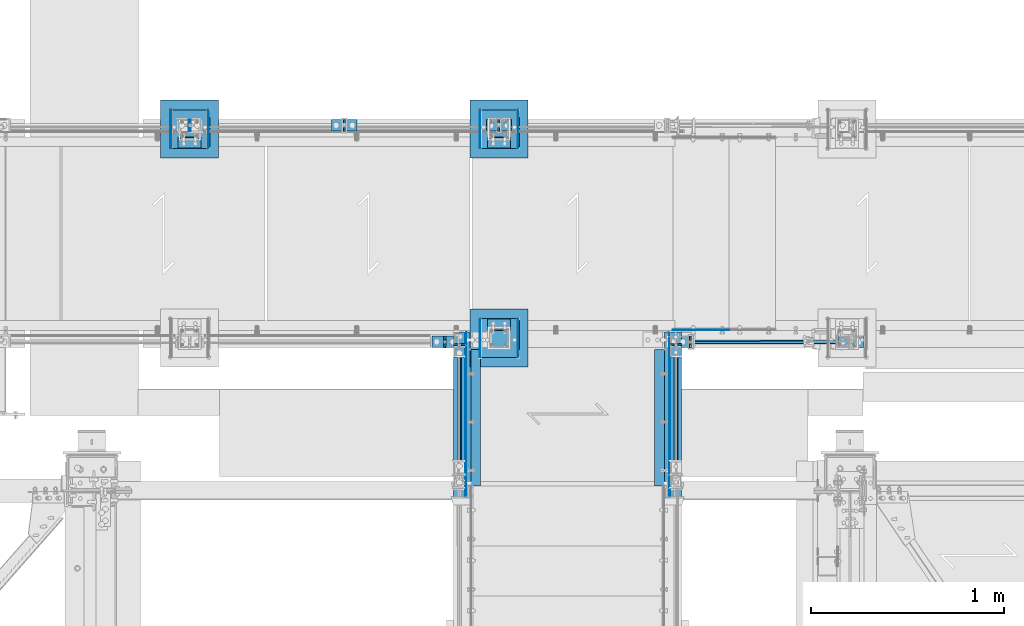
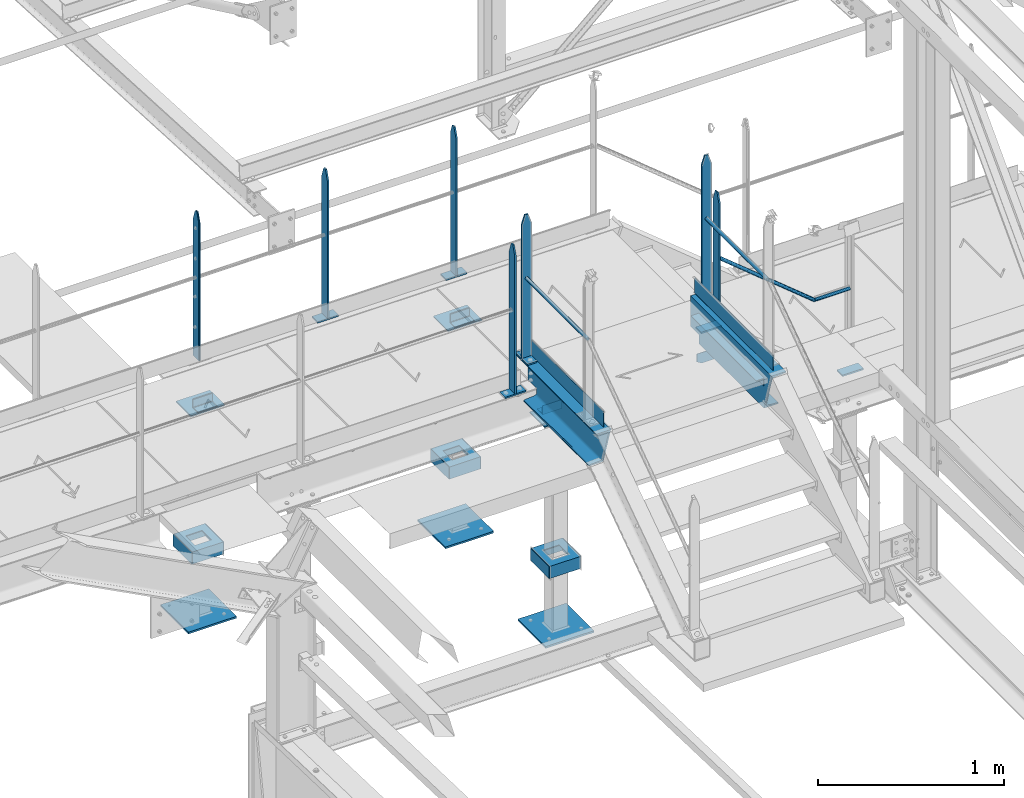
# One storey, part 97 of 496: 43 beams, 1 member, 18 elements without a shape of their own.
"""IFC2X3 building model written with IfcOpenShell, lengths in millimetres."""

from ifc_helpers import new_model, si_unit, frame, origin_with_axes, origin_2d_with_axis, place, context, subcontext, project, spatial, polyline, rectangle, hollow_circle, l_section, u_section, outline, extrude, boolean, clip, halfspace, material, type_object, element, aggregate, save


model = new_model("IFC2X3")

# Units and contexts
model_context = context("Model", 3, precision=1e-05, world=origin_with_axes())
body_context = subcontext(model_context, "Body", "Model", "MODEL_VIEW")
ifc_project = project(units=[si_unit("LENGTHUNIT", "METRE", prefix="MILLI"), si_unit("AREAUNIT", "SQUARE_METRE"), si_unit("VOLUMEUNIT", "CUBIC_METRE"), si_unit("MASSUNIT", "GRAM", prefix="KILO"), si_unit("TIMEUNIT", "SECOND"), si_unit("PLANEANGLEUNIT", "RADIAN"), si_unit("SOLIDANGLEUNIT", "STERADIAN"), si_unit("THERMODYNAMICTEMPERATUREUNIT", "DEGREE_CELSIUS"), si_unit("LUMINOUSINTENSITYUNIT", "LUMEN")], contexts=[model_context])

# Site, building, storey
site_placement = place(None, origin_with_axes())
site = spatial("IfcSite", under=ifc_project, at=site_placement, CompositionType="ELEMENT")
building_placement = place(site_placement, origin_with_axes())
building = spatial("IfcBuilding", under=site, at=building_placement, Name="Undefined", CompositionType="ELEMENT")
storey_placement = place(building_placement, origin_with_axes())
storey = spatial("IfcBuildingStorey", under=building, at=storey_placement, Name="Undefined", CompositionType="ELEMENT", Elevation=0.0)

# Assembly, beam
assembly_1_placement = place(storey_placement, origin_with_axes())
assembly_1 = element("IfcElementAssembly", 1, at=assembly_1_placement, inside=storey, Name="MAIN COURANTE", AssemblyPlace="NOTDEFINED", PredefinedType="NOTDEFINED")
ifc_material_1 = material(Name="Undefined/S235-E24")
beam_type_1 = type_object("IfcBeamType", PredefinedType="NOTDEFINED")
beam_1_placement = place(assembly_1_placement, frame((21439.9851177233, 15970.0000882977, 8705.00000001012), z_axis=(0.0, -1.0, 0.0), x_axis=(-1.0, 0.0, 0.0)))
beam_1 = element("IfcBeam", 2, at=beam_1_placement, type_object=beam_type_1, material=ifc_material_1, context=body_context, shape_type="SweptSolid", body=[
    extrude(rectangle(XDim=10.0, YDim=60.0, at=origin_2d_with_axis()), frame((130.0, 0.0, 0.0), z_axis=(-1.0, 0.0, 0.0), x_axis=(0.0, -1.0, 0.0)), (0.0, 0.0, 1.0), 130.0),
])
aggregate(assembly_1, [beam_1])

assembly_2_placement = place(storey_placement, origin_with_axes())
assembly_2 = element("IfcElementAssembly", 3, at=assembly_2_placement, inside=storey, Name="MONTANT", AssemblyPlace="NOTDEFINED", PredefinedType="NOTDEFINED")
beam_2_placement = place(assembly_2_placement, frame((21374.9851177233, 15970.0000882977, 9677.59999847), z_axis=(0.0, 1.0, 0.0), x_axis=(0.0, 0.0, -1.0)))
beam_2 = element("IfcBeam", 4, at=beam_2_placement, type_object=beam_type_1, material=ifc_material_1, Name="MONTANT", context=body_context, shape_type="Clipping", body=[
    clip(clip(extrude(rectangle(XDim=10.0, YDim=60.0, at=origin_2d_with_axis()), frame((967.599838858492, 0.0, 0.0), z_axis=(-1.0, 0.0, 0.0), x_axis=(0.0, -1.0, 0.0)), (0.0, 0.0, 1.0), 967.6), halfspace(frame((-119.99851575355, 5.0, -30.0), z_axis=(-0.316227766016838, 0.0, 0.948683298050514), x_axis=(0.948683298050514, 0.0, 0.316227766016838)), False)), halfspace(frame((60.0014842464498, 5.0, -30.0), z_axis=(-0.316227766016838, 0.0, -0.948683298050514), x_axis=(-0.948683298050514, 0.0, 0.316227766016838)), False)),
])
aggregate(assembly_2, [beam_2])

# Assembly, beams
assembly_3_placement = place(storey_placement, origin_with_axes())
assembly_3 = element("IfcElementAssembly", 5, at=assembly_3_placement, inside=storey, Name="MAIN COURANTE", AssemblyPlace="NOTDEFINED", PredefinedType="NOTDEFINED")
beam_3_placement = place(assembly_3_placement, frame((22660.0061849194, 15970.0000882977, 8705.00015961151), z_axis=(0.0, -1.0, 0.0), x_axis=(-1.0, 0.0, 0.0)))
beam_3 = element("IfcBeam", 6, at=beam_3_placement, type_object=beam_type_1, material=ifc_material_1, context=body_context, shape_type="SweptSolid", body=[
    extrude(rectangle(XDim=10.0, YDim=60.0, at=origin_2d_with_axis()), frame((130.0, 0.0, 0.0), z_axis=(-1.0, 0.0, 0.0), x_axis=(0.0, -1.0, 0.0)), (0.0, 0.0, 1.0), 130.0),
])
beam_4_placement = place(assembly_3_placement, frame((22645.0061849194, 15970.0000882977, 9582.39164232764), z_axis=(0.0, 1.0, 0.0), x_axis=(0.0, 0.0, -1.0)))
beam_4 = element("IfcBeam", 7, at=beam_4_placement, type_object=beam_type_1, material=ifc_material_1, Name="MONTANT", context=body_context, shape_type="Clipping", body=[
    clip(clip(clip(extrude(rectangle(XDim=10.0, YDim=60.0, at=origin_2d_with_axis()), frame((872.391482716137, 0.0, 0.0), z_axis=(-1.0, 0.0, 0.0), x_axis=(0.0, -1.0, 0.0)), (0.0, 0.0, 1.0), 876.53), halfspace(frame((-119.99851575355, -5.0, -30.0), z_axis=(-0.316227766016838, 0.0, 0.948683298050514), x_axis=(0.0, 1.0, 0.0)), False)), halfspace(frame((60.0014842464498, -5.0, -30.0), z_axis=(-0.316227766016838, 0.0, -0.948683298050514), x_axis=(0.0, 1.0, 0.0)), False)), halfspace(frame((7.28321514399249, -8.88829265710956, 0.0), z_axis=(0.773488973625628, 0.633809756693262, 0.0), x_axis=(0.0, 0.0, 1.0)), True)),
])
beam_5_placement = place(assembly_3_placement, frame((23540.0061849194, 15970.0000882977, 8114.9999407569), z_axis=(0.0, -1.0, 0.0), x_axis=(-1.0, 0.0, 0.0)))
beam_5 = element("IfcBeam", 8, at=beam_5_placement, type_object=beam_type_1, material=ifc_material_1, context=body_context, shape_type="SweptSolid", body=[
    extrude(rectangle(XDim=10.0, YDim=60.0, at=origin_2d_with_axis()), frame((130.0, 0.0, 0.0), z_axis=(-1.0, 0.0, 0.0), x_axis=(0.0, -1.0, 0.0)), (0.0, 0.0, 1.0), 130.0),
])

assembly_4_placement = place(storey_placement, origin_with_axes())
assembly_4 = element("IfcElementAssembly", 9, at=assembly_4_placement, inside=storey, Name="MAIN COURANTE", AssemblyPlace="NOTDEFINED", PredefinedType="NOTDEFINED")
beam_6_placement = place(assembly_4_placement, frame((20919.9961849193, 17089.9938659712, 8705.00000001012), z_axis=(0.0, 1.0, 0.0), x_axis=(-1.0, 0.0, 0.0)))
beam_6 = element("IfcBeam", 10, at=beam_6_placement, type_object=beam_type_1, material=ifc_material_1, context=body_context, shape_type="SweptSolid", body=[
    extrude(rectangle(XDim=10.0, YDim=60.0, at=origin_2d_with_axis()), frame((130.0, 0.0, 0.0), z_axis=(-1.0, 0.0, 0.0), x_axis=(0.0, -1.0, 0.0)), (0.0, 0.0, 1.0), 130.0),
])
beam_7_placement = place(assembly_4_placement, frame((20854.9961849193, 17089.9938659712, 9677.59999847), z_axis=(0.0, -1.0, 0.0), x_axis=(0.0, 0.0, -1.0)))
beam_7 = element("IfcBeam", 11, at=beam_7_placement, type_object=beam_type_1, material=ifc_material_1, Name="MONTANT", context=body_context, shape_type="Clipping", body=[
    clip(clip(extrude(rectangle(XDim=10.0, YDim=60.0, at=origin_2d_with_axis()), frame((967.59999845988, 0.0, 0.0), z_axis=(-1.0, 0.0, 0.0), x_axis=(0.0, -1.0, 0.0)), (0.0, 0.0, 1.0), 967.6), halfspace(frame((-120.0, 5.0, -30.0), z_axis=(-0.316227766016838, 0.0, 0.948683298050514), x_axis=(0.948683298050514, 0.0, 0.316227766016838)), False)), halfspace(frame((60.0, 5.0, -30.0), z_axis=(-0.316227766016838, 0.0, -0.948683298050514), x_axis=(-0.948683298050514, 0.0, 0.316227766016838)), False)),
])
beam_8_placement = place(assembly_4_placement, frame((21719.9961849193, 17089.9938659712, 8705.00000001012), z_axis=(0.0, 1.0, 0.0), x_axis=(-1.0, 0.0, 0.0)))
beam_8 = element("IfcBeam", 12, at=beam_8_placement, type_object=beam_type_1, material=ifc_material_1, context=body_context, shape_type="SweptSolid", body=[
    extrude(rectangle(XDim=10.0, YDim=60.0, at=origin_2d_with_axis()), frame((130.0, 0.0, 0.0), z_axis=(-1.0, 0.0, 0.0), x_axis=(0.0, -1.0, 0.0)), (0.0, 0.0, 1.0), 130.0),
])

assembly_5_placement = place(storey_placement, origin_with_axes())
assembly_5 = element("IfcElementAssembly", 13, at=assembly_5_placement, inside=storey, Name="MAIN COURANTE", AssemblyPlace="NOTDEFINED", PredefinedType="NOTDEFINED")
beam_9_placement = place(assembly_5_placement, frame((21449.9863365012, 16019.9996531834, 8915.0), z_axis=(-1.0, 0.0, 0.0), x_axis=(0.0, -1.0, 0.0)))
beam_9 = element("IfcBeam", 14, at=beam_9_placement, type_object=beam_type_1, material=ifc_material_1, context=body_context, shape_type="SweptSolid", body=[
    extrude(rectangle(XDim=10.0, YDim=60.0, at=origin_2d_with_axis()), frame((130.0, 0.0, 0.0), z_axis=(-1.0, 0.0, 0.0), x_axis=(0.0, -1.0, 0.0)), (0.0, 0.0, 1.0), 130.0),
])
beam_10_placement = place(assembly_5_placement, frame((21449.9862112009, 15954.9996531834, 9857.59999847), z_axis=(-0.99999999999782, -2.08799998896818e-06, 0.0), x_axis=(0.0, 0.0, -1.0)))
beam_10 = element("IfcBeam", 15, at=beam_10_placement, type_object=beam_type_1, material=ifc_material_1, Name="MONTANT", context=body_context, shape_type="Clipping", body=[
    clip(clip(extrude(rectangle(XDim=10.0, YDim=60.0, at=origin_2d_with_axis()), frame((937.599998469999, 0.0, 0.0), z_axis=(-1.0, 0.0, 0.0), x_axis=(0.0, -1.0, 0.0)), (0.0, 0.0, 1.0), 937.6), halfspace(frame((-119.999937359999, -4.99999999999636, -30.0), z_axis=(-0.316227766016837, -1.98085072276202e-06, 0.948683298048446), x_axis=(-6.26399999950979e-06, 0.999999999980381, -3.63797880701241e-15)), False)), halfspace(frame((60.0, -5.0, -30.0), z_axis=(-0.316227469016822, 1.98084886235393e-06, -0.948683397048399), x_axis=(6.26399999950979e-06, 0.999999999980381, -3.63797880701241e-15)), False)),
])

assembly_6_placement = place(storey_placement, origin_with_axes())
assembly_6 = element("IfcElementAssembly", 16, at=assembly_6_placement, inside=storey, Name="MAIN COURANTE", AssemblyPlace="NOTDEFINED", PredefinedType="NOTDEFINED")
beam_11_placement = place(assembly_6_placement, frame((22569.9936634988, 16019.9996531834, 8915.0), z_axis=(1.0, 0.0, 0.0), x_axis=(0.0, -1.0, 0.0)))
beam_11 = element("IfcBeam", 17, at=beam_11_placement, type_object=beam_type_1, material=ifc_material_1, context=body_context, shape_type="SweptSolid", body=[
    extrude(rectangle(XDim=10.0, YDim=60.0, at=origin_2d_with_axis()), frame((130.0, 0.0, 0.0), z_axis=(-1.0, 0.0, 0.0), x_axis=(0.0, -1.0, 0.0)), (0.0, 0.0, 1.0), 130.0),
])
beam_12_placement = place(assembly_6_placement, frame((22569.9937887991, 15954.9996531834, 9857.59999847), z_axis=(0.999999999998558, -1.69800000185205e-06, 0.0), x_axis=(0.0, 0.0, -1.0)))
beam_12 = element("IfcBeam", 18, at=beam_12_placement, type_object=beam_type_1, material=ifc_material_1, Name="MONTANT", context=body_context, shape_type="Clipping", body=[
    clip(clip(extrude(rectangle(XDim=10.0, YDim=60.0, at=origin_2d_with_axis()), frame((937.599998469999, 0.0, 0.0), z_axis=(-1.0, 0.0, 0.0), x_axis=(0.0, -1.0, 0.0)), (0.0, 0.0, 1.0), 937.6), halfspace(frame((-119.999937359999, 4.99999999999818, -30.0), z_axis=(-0.316227766016843, 1.98085072621335e-06, 0.948683298048444), x_axis=(0.948683298050514, 0.0, 0.316227766016838)), False)), halfspace(frame((60.0, 5.0, -30.0), z_axis=(-0.316227469016822, -1.98084886580522e-06, -0.948683397048399), x_axis=(-0.948683298050514, 0.0, 0.316227766016838)), False)),
])

# Beam
beam_13_placement = place(assembly_4_placement, frame((21654.9961849193, 17089.9938659712, 9677.59999847), z_axis=(0.0, -1.0, 0.0), x_axis=(0.0, 0.0, -1.0)))
beam_13 = element("IfcBeam", 19, at=beam_13_placement, type_object=beam_type_1, material=ifc_material_1, Name="MONTANT", context=body_context, shape_type="Clipping", body=[
    clip(clip(extrude(rectangle(XDim=10.0, YDim=60.0, at=origin_2d_with_axis()), frame((967.59999845988, 0.0, 0.0), z_axis=(-1.0, 0.0, 0.0), x_axis=(0.0, -1.0, 0.0)), (0.0, 0.0, 1.0), 967.6), halfspace(frame((-120.0, 5.0, -30.0), z_axis=(-0.316227766016838, 0.0, 0.948683298050514), x_axis=(0.948683298050514, 0.0, 0.316227766016838)), False)), halfspace(frame((60.0, 5.0, -30.0), z_axis=(-0.316227766016838, 0.0, -0.948683298050514), x_axis=(-0.948683298050514, 0.0, 0.316227766016838)), False)),
])

beam_type_2 = type_object("IfcBeamType", PredefinedType="NOTDEFINED")
beam_14_placement = place(assembly_3_placement, frame((23250.3145397259, 15970.0002031579, 8653.80000001012), z_axis=(0.0, -1.0, 0.0), x_axis=(1.0, 0.0, 0.0)))
beam_14 = element("IfcBeam", 20, at=beam_14_placement, type_object=beam_type_2, material=ifc_material_1, Name="LISSE", context=body_context, shape_type="Clipping", body=[
    clip(extrude(hollow_circle(Radius=10.64999962, WallThickness=2.0, at=origin_2d_with_axis()), frame((219.691645193617, 1.81898940354586e-12, 0.0), z_axis=(-1.0, 0.0, 0.0), x_axis=(0.0, -1.0, 0.0)), (0.0, 0.0, 1.0), 223.54), halfspace(frame((3.80609846942389, 10.6499996200018, 0.000112519470349071), z_axis=(0.941671113820085, -0.336534564935766, -5.79127735785473e-07), x_axis=(-0.336534564313756, -0.941671114042557, 0.0)), True)),
])

beam_15_placement = place(assembly_6_placement, frame((22569.9936634988, 15290.0038659711, 9438.8), z_axis=(0.999999999998558, -1.69800000185205e-06, 0.0), x_axis=(1.69800000215235e-06, 0.999999999998558, 0.0)))
beam_15 = element("IfcBeam", 21, at=beam_15_placement, type_object=beam_type_2, material=ifc_material_1, Name="LISSE", context=body_context, shape_type="SweptSolid", body=[
    extrude(hollow_circle(Radius=10.64999962, WallThickness=2.0, at=origin_2d_with_axis()), frame((659.995802516527, 1.81898940354586e-12, -1.3975954744526e-19), z_axis=(-1.0, 0.0, 0.0), x_axis=(0.0, -1.0, 0.0)), (0.0, 0.0, 1.0), 660.0),
])

beam_16_placement = place(assembly_5_placement, frame((21449.9863365012, 15290.0038659711, 9438.8), z_axis=(-0.99999999999782, -2.08799998896818e-06, 0.0), x_axis=(-1.15500000027281e-06, 0.999999999999333, 0.0)))
beam_16 = element("IfcBeam", 22, at=beam_16_placement, type_object=beam_type_2, material=ifc_material_1, Name="LISSE", context=body_context, shape_type="SweptSolid", body=[
    extrude(hollow_circle(Radius=10.64999962, WallThickness=2.0, at=origin_2d_with_axis()), frame((659.995802516527, 1.81898940354586e-12, -1.3975954744526e-19), z_axis=(-1.0, 0.0, 0.0), x_axis=(0.0, -1.0, 0.0)), (0.0, 0.0, 1.0), 660.0),
])

# Member
member_type = type_object("IfcMemberType", PredefinedType="NOTDEFINED")
member_placement = place(assembly_3_placement, frame((23250.3145397259, 15970.0040747151, 8653.80000001012), z_axis=(0.0, 1.0, 0.0), x_axis=(-0.773488973625643, 0.0, 0.633809756693245)))
member = element("IfcMember", 23, at=member_placement, type_object=member_type, material=ifc_material_1, Name="LISSE", context=body_context, shape_type="Clipping", body=[
    clip(clip(extrude(hollow_circle(Radius=10.64999962, WallThickness=2.0, at=origin_2d_with_axis()), frame((794.709650012954, 0.0, 0.0), z_axis=(-1.0, 0.0, 0.0), x_axis=(0.0, -1.0, 0.0)), (0.0, 0.0, 1.0), 813.31), halfspace(frame((787.048146301975, 13.3552820560435, -0.00398641746141948), z_axis=(-0.773488973625642, 0.633809756693246, 0.0), x_axis=(-0.633809756693246, -0.773488973625642, 0.0)), True)), halfspace(frame((3.80609846935113, 10.6499996200037, -0.00398641746141948), z_axis=(-0.941671114042557, 0.336534564313756, 0.0), x_axis=(-0.336534564313756, -0.941671114042557, 0.0)), False)),
])

aggregate(assembly_3, [beam_3, beam_4, beam_5, member, beam_14])

# Assembly, beam
assembly_7_placement = place(storey_placement, origin_with_axes())
assembly_7 = element("IfcElementAssembly", 24, at=assembly_7_placement, inside=storey, AssemblyPlace="NOTDEFINED", PredefinedType="NOTDEFINED")
beam_type_3 = type_object("IfcBeamType", PredefinedType="NOTDEFINED")
beam_17_placement = place(assembly_7_placement, frame((20205.0, 17219.9998774248, 7056.0), z_axis=(0.0, 0.0, 1.0), x_axis=(-1.0, 0.0, 0.0)))
beam_17 = element("IfcBeam", 25, at=beam_17_placement, type_object=beam_type_3, material=ifc_material_1, context=body_context, shape_type="SweptSolid", body=[
    extrude(outline(polyline([(0.0, 0.0), (300.0, 0.0), (300.0, 300.0), (0.0, 300.0), (0.0, 0.0)])), frame((0.0, 0.0, -6.0), z_axis=(0.0, 0.0, 1.0), x_axis=(1.0, 0.0, 0.0)), (0.0, 0.0, 1.0), 12.0),
])

assembly_8_placement = place(storey_placement, origin_with_axes())
assembly_8 = element("IfcElementAssembly", 26, at=assembly_8_placement, inside=storey, AssemblyPlace="NOTDEFINED", PredefinedType="NOTDEFINED")
beam_18_placement = place(assembly_8_placement, frame((21805.0, 15840.0001225752, 7056.0), z_axis=(0.0, 0.0, -1.0), x_axis=(-1.0, 0.0, 0.0)))
beam_18 = element("IfcBeam", 27, at=beam_18_placement, type_object=beam_type_3, material=ifc_material_1, context=body_context, shape_type="SweptSolid", body=[
    extrude(outline(polyline([(0.0, 0.0), (300.0, 0.0), (300.0, 300.0), (0.0, 300.0), (0.0, 0.0)])), frame((0.0, 0.0, -6.0), z_axis=(0.0, 0.0, 1.0), x_axis=(1.0, 0.0, 0.0)), (0.0, 0.0, 1.0), 12.0),
])

assembly_9_placement = place(storey_placement, origin_with_axes())
assembly_9 = element("IfcElementAssembly", 28, at=assembly_9_placement, inside=storey, AssemblyPlace="NOTDEFINED", PredefinedType="NOTDEFINED")
beam_19_placement = place(assembly_9_placement, frame((21805.0, 17219.9998774248, 7056.0), z_axis=(0.0, 0.0, 1.0), x_axis=(-1.0, 0.0, 0.0)))
beam_19 = element("IfcBeam", 29, at=beam_19_placement, type_object=beam_type_3, material=ifc_material_1, context=body_context, shape_type="SweptSolid", body=[
    extrude(outline(polyline([(0.0, 0.0), (300.0, 0.0), (300.0, 300.0), (0.0, 300.0), (0.0, 0.0)])), frame((0.0, 0.0, -6.0), z_axis=(0.0, 0.0, 1.0), x_axis=(1.0, 0.0, 0.0)), (0.0, 0.0, 1.0), 12.0),
])

# Beam
beam_type_4 = type_object("IfcBeamType", PredefinedType="NOTDEFINED")
beam_20_placement = place(assembly_5_placement, frame((21482.4987221813, 16019.9997158234, 8970.0), z_axis=(0.0, 0.0, -1.0), x_axis=(0.0, -1.0, 0.0)))
beam_20 = element("IfcBeam", 30, at=beam_20_placement, type_object=beam_type_4, material=ifc_material_1, context=body_context, shape_type="SweptSolid", body=[
    extrude(rectangle(XDim=5.0, YDim=100.0, at=origin_2d_with_axis()), frame((844.999940076701, 0.0, 0.0), z_axis=(-1.0, 0.0, 0.0), x_axis=(0.0, -1.0, 0.0)), (0.0, 0.0, 1.0), 845.0),
])

aggregate(assembly_5, [beam_16, beam_20, beam_9, beam_10])

beam_21_placement = place(assembly_6_placement, frame((22537.4812778187, 16019.9997158234, 8970.0), z_axis=(0.0, 0.0, -1.0), x_axis=(0.0, -1.0, 0.0)))
beam_21 = element("IfcBeam", 31, at=beam_21_placement, type_object=beam_type_4, material=ifc_material_1, context=body_context, shape_type="SweptSolid", body=[
    extrude(rectangle(XDim=5.0, YDim=100.0, at=origin_2d_with_axis()), frame((844.999940076701, 0.0, 0.0), z_axis=(-1.0, 0.0, 0.0), x_axis=(0.0, -1.0, 0.0)), (0.0, 0.0, 1.0), 845.0),
])

aggregate(assembly_6, [beam_15, beam_21, beam_11, beam_12])

beam_type_5 = type_object("IfcBeamType", PredefinedType="NOTDEFINED")
beam_22_placement = place(assembly_4_placement, frame((20057.4961849193, 17089.9938659712, 9677.59999847), z_axis=(0.0, -1.0, 0.0), x_axis=(0.0, 0.0, -1.0)))
beam_22 = element("IfcBeam", 32, at=beam_22_placement, type_object=beam_type_5, material=ifc_material_1, Name="MONTANT", context=body_context, shape_type="Clipping", body=[
    clip(clip(extrude(rectangle(XDim=5.0, YDim=60.0, at=origin_2d_with_axis()), frame((967.59999845988, 0.0, 0.0), z_axis=(-1.0, 0.0, 0.0), x_axis=(0.0, -1.0, 0.0)), (0.0, 0.0, 1.0), 967.6), halfspace(frame((-120.0, -5.0, -30.0), z_axis=(-0.316227766016838, 0.0, 0.948683298050514), x_axis=(0.0, 1.0, 0.0)), False)), halfspace(frame((60.0, -5.0, -30.0), z_axis=(-0.316227766016838, 0.0, -0.948683298050514), x_axis=(0.0, 1.0, 0.0)), False)),
])

aggregate(assembly_4, [beam_22, beam_6, beam_7, beam_8, beam_13])

# Assembly, beam
assembly_10_placement = place(storey_placement, origin_with_axes())
assembly_10 = element("IfcElementAssembly", 33, at=assembly_10_placement, inside=storey, Name="MAIN COURANTE", AssemblyPlace="NOTDEFINED", PredefinedType="NOTDEFINED")
beam_23_placement = place(assembly_10_placement, frame((20052.4961849157, 17089.9938659712, 9677.59999847), z_axis=(0.0, -1.0, 0.0), x_axis=(0.0, 0.0, -1.0)))
beam_23 = element("IfcBeam", 34, at=beam_23_placement, type_object=beam_type_5, material=ifc_material_1, Name="MONTANT", context=body_context, shape_type="Clipping", body=[
    clip(clip(extrude(rectangle(XDim=5.0, YDim=60.0, at=origin_2d_with_axis()), frame((967.59999845988, 0.0, 0.0), z_axis=(-1.0, 0.0, 0.0), x_axis=(0.0, -1.0, 0.0)), (0.0, 0.0, 1.0), 967.6), halfspace(frame((-120.0, 5.0, -30.0), z_axis=(-0.316227766016838, 0.0, 0.948683298050514), x_axis=(0.948683298050514, 0.0, 0.316227766016838)), False)), halfspace(frame((60.0, 5.0, -30.0), z_axis=(-0.316227766016838, 0.0, -0.948683298050514), x_axis=(-0.948683298050514, 0.0, 0.316227766016838)), False)),
])
aggregate(assembly_10, [beam_23])

# Beam
beam_type_6 = type_object("IfcBeamType", PredefinedType="NOTDEFINED")
beam_24_placement = place(assembly_7_placement, frame((20160.0, 17129.9993585039, 8436.00011661134), z_axis=(0.0, 0.0, 1.0), x_axis=(-1.0, 0.0, 0.0)))
beam_24 = element("IfcBeam", 35, at=beam_24_placement, type_object=beam_type_6, material=ifc_material_1, context=body_context, shape_type="SweptSolid", body=[
    extrude(outline(polyline([(0.0, 0.0), (210.0, 0.0), (210.0, 159.999481201172), (0.0, 159.999481201172), (0.0, 0.0)])), frame((0.0, 0.0, -4.0), z_axis=(0.0, 0.0, 1.0), x_axis=(1.0, 0.0, 0.0)), (0.0, 0.0, 1.0), 8.0),
])

beam_25_placement = place(assembly_8_placement, frame((21760.0, 15930.0006414961, 8436.00011661134), z_axis=(0.0, 0.0, -1.0), x_axis=(-1.0, 0.0, 0.0)))
beam_25 = element("IfcBeam", 36, at=beam_25_placement, type_object=beam_type_6, material=ifc_material_1, context=body_context, shape_type="SweptSolid", body=[
    extrude(outline(polyline([(0.0, 0.0), (210.0, 0.0), (210.0, 159.999481201172), (0.0, 159.999481201172), (0.0, 0.0)])), frame((0.0, 0.0, -4.0), z_axis=(0.0, 0.0, 1.0), x_axis=(1.0, 0.0, 0.0)), (0.0, 0.0, 1.0), 8.0),
])

beam_26_placement = place(assembly_9_placement, frame((21760.0, 17129.9993585039, 8436.00011661134), z_axis=(0.0, 0.0, 1.0), x_axis=(-1.0, 0.0, 0.0)))
beam_26 = element("IfcBeam", 37, at=beam_26_placement, type_object=beam_type_6, material=ifc_material_1, context=body_context, shape_type="SweptSolid", body=[
    extrude(outline(polyline([(0.0, 0.0), (210.0, 0.0), (210.0, 159.999481201172), (0.0, 159.999481201172), (0.0, 0.0)])), frame((0.0, 0.0, -4.0), z_axis=(0.0, 0.0, 1.0), x_axis=(1.0, 0.0, 0.0)), (0.0, 0.0, 1.0), 8.0),
])

beam_type_7 = type_object("IfcBeamType", PredefinedType="NOTDEFINED")
beam_27_placement = place(assembly_7_placement, frame((20153.0, 16969.9998774248, 7500.0), z_axis=(0.0, 0.0, 1.0), x_axis=(0.0, 1.0, 0.0)))
beam_27 = element("IfcBeam", 38, at=beam_27_placement, type_object=beam_type_7, material=ifc_material_1, Name="BORD", context=body_context, shape_type="SweptSolid", body=[
    extrude(rectangle(XDim=4.0, YDim=80.0, at=origin_2d_with_axis()), frame((200.0, 0.0, 0.0), z_axis=(-1.0, 0.0, 0.0), x_axis=(0.0, -1.0, 0.0)), (0.0, 0.0, 1.0), 200.0),
])

beam_28_placement = place(assembly_7_placement, frame((19957.0, 16969.9998774248, 7500.0), z_axis=(0.0, 0.0, 1.0), x_axis=(0.0, 1.0, 0.0)))
beam_28 = element("IfcBeam", 39, at=beam_28_placement, type_object=beam_type_7, material=ifc_material_1, Name="BORD", context=body_context, shape_type="SweptSolid", body=[
    extrude(rectangle(XDim=4.0, YDim=80.0, at=origin_2d_with_axis()), frame((200.0, 0.0, 0.0), z_axis=(-1.0, 0.0, 0.0), x_axis=(0.0, -1.0, 0.0)), (0.0, 0.0, 1.0), 200.0),
])

beam_29_placement = place(assembly_8_placement, frame((21753.0, 16090.0001225752, 7500.0), z_axis=(0.0, 0.0, 1.0), x_axis=(0.0, -1.0, 0.0)))
beam_29 = element("IfcBeam", 40, at=beam_29_placement, type_object=beam_type_7, material=ifc_material_1, Name="BORD", context=body_context, shape_type="SweptSolid", body=[
    extrude(rectangle(XDim=4.0, YDim=80.0, at=origin_2d_with_axis()), frame((200.0, 0.0, 0.0), z_axis=(-1.0, 0.0, 0.0), x_axis=(0.0, -1.0, 0.0)), (0.0, 0.0, 1.0), 200.0),
])

beam_30_placement = place(assembly_8_placement, frame((21557.0, 16090.0001225752, 7500.0), z_axis=(0.0, 0.0, 1.0), x_axis=(0.0, -1.0, 0.0)))
beam_30 = element("IfcBeam", 41, at=beam_30_placement, type_object=beam_type_7, material=ifc_material_1, Name="BORD", context=body_context, shape_type="SweptSolid", body=[
    extrude(rectangle(XDim=4.0, YDim=80.0, at=origin_2d_with_axis()), frame((200.0, 0.0, 0.0), z_axis=(-1.0, 0.0, 0.0), x_axis=(0.0, -1.0, 0.0)), (0.0, 0.0, 1.0), 200.0),
])

beam_31_placement = place(assembly_9_placement, frame((21753.0, 16969.9998774248, 7500.0), z_axis=(0.0, 0.0, 1.0), x_axis=(0.0, 1.0, 0.0)))
beam_31 = element("IfcBeam", 42, at=beam_31_placement, type_object=beam_type_7, material=ifc_material_1, Name="BORD", context=body_context, shape_type="SweptSolid", body=[
    extrude(rectangle(XDim=4.0, YDim=80.0, at=origin_2d_with_axis()), frame((200.0, 0.0, 0.0), z_axis=(-1.0, 0.0, 0.0), x_axis=(0.0, -1.0, 0.0)), (0.0, 0.0, 1.0), 200.0),
])

beam_32_placement = place(assembly_9_placement, frame((21557.0, 16969.9998774248, 7500.0), z_axis=(0.0, 0.0, 1.0), x_axis=(0.0, 1.0, 0.0)))
beam_32 = element("IfcBeam", 43, at=beam_32_placement, type_object=beam_type_7, material=ifc_material_1, Name="BORD", context=body_context, shape_type="SweptSolid", body=[
    extrude(rectangle(XDim=4.0, YDim=80.0, at=origin_2d_with_axis()), frame((200.0, 0.0, 0.0), z_axis=(-1.0, 0.0, 0.0), x_axis=(0.0, -1.0, 0.0)), (0.0, 0.0, 1.0), 200.0),
])

beam_type_8 = type_object("IfcBeamType", PredefinedType="NOTDEFINED")
beam_33_placement = place(assembly_7_placement, frame((19959.0, 17069.9998774248, 7500.0), z_axis=(0.0, -1.0, 0.0), x_axis=(1.0, 0.0, 0.0)))
beam_33 = element("IfcBeam", 44, at=beam_33_placement, type_object=beam_type_8, material=ifc_material_1, context=body_context, shape_type="CSG", body=[
    boolean("DIFFERENCE", extrude(u_section(Depth=200.0, FlangeWidth=80.0, WebThickness=4.0, FlangeThickness=4.0, at=origin_2d_with_axis()), frame((192.0, 0.0, 0.0), z_axis=(-1.0, 0.0, 0.0), x_axis=(0.0, -1.0, 0.0)), (0.0, 0.0, 1.0), 192.0), extrude(outline(polyline([(0.0, 0.0), (101.0, 0.0), (101.0, 101.0), (0.0, 101.0), (0.0, 0.0)])), frame((45.5, -42.5, -50.5), z_axis=(0.0, 1.0, 0.0), x_axis=(0.0, 0.0, 1.0)), (0.0, 0.0, 1.0), 85.0)),
])

aggregate(assembly_7, [beam_24, beam_27, beam_28, beam_33, beam_17])

beam_34_placement = place(assembly_8_placement, frame((21751.0, 15990.0001225752, 7500.0), z_axis=(0.0, 1.0, 0.0), x_axis=(-1.0, 0.0, 0.0)))
beam_34 = element("IfcBeam", 45, at=beam_34_placement, type_object=beam_type_8, material=ifc_material_1, context=body_context, shape_type="CSG", body=[
    boolean("DIFFERENCE", extrude(u_section(Depth=200.0, FlangeWidth=80.0, WebThickness=4.0, FlangeThickness=4.0, at=origin_2d_with_axis()), frame((192.0, 0.0, 0.0), z_axis=(-1.0, 0.0, 0.0), x_axis=(0.0, -1.0, 0.0)), (0.0, 0.0, 1.0), 192.0), extrude(outline(polyline([(0.0, 0.0), (101.0, 0.0), (101.0, 101.0), (0.0, 101.0), (0.0, 0.0)])), frame((146.5, -42.5, 50.5), z_axis=(0.0, 1.0, 0.0), x_axis=(0.0, 0.0, -1.0)), (0.0, 0.0, 1.0), 85.0)),
])

aggregate(assembly_8, [beam_25, beam_29, beam_30, beam_34, beam_18])

beam_35_placement = place(assembly_9_placement, frame((21559.0, 17069.9998774248, 7500.0), z_axis=(0.0, -1.0, 0.0), x_axis=(1.0, 0.0, 0.0)))
beam_35 = element("IfcBeam", 46, at=beam_35_placement, type_object=beam_type_8, material=ifc_material_1, context=body_context, shape_type="CSG", body=[
    boolean("DIFFERENCE", extrude(u_section(Depth=200.0, FlangeWidth=80.0, WebThickness=4.0, FlangeThickness=4.0, at=origin_2d_with_axis()), frame((192.0, 0.0, 0.0), z_axis=(-1.0, 0.0, 0.0), x_axis=(0.0, -1.0, 0.0)), (0.0, 0.0, 1.0), 192.0), extrude(outline(polyline([(0.0, 0.0), (101.0, 0.0), (101.0, 101.0), (0.0, 101.0), (0.0, 0.0)])), frame((45.5, -42.5, -50.5), z_axis=(0.0, 1.0, 0.0), x_axis=(0.0, 0.0, 1.0)), (0.0, 0.0, 1.0), 85.0)),
])

aggregate(assembly_9, [beam_26, beam_31, beam_32, beam_35, beam_19])

# Assembly, beam
assembly_11_placement = place(storey_placement, origin_with_axes())
assembly_11 = element("IfcElementAssembly", 47, at=assembly_11_placement, inside=storey, Name="SUPPORT", AssemblyPlace="NOTDEFINED", PredefinedType="NOTDEFINED")
beam_type_9 = type_object("IfcBeamType", PredefinedType="NOTDEFINED")
beam_36_placement = place(assembly_11_placement, frame((22484.9814327271, 15930.0058468547, 8825.0), z_axis=(-1.0, 0.0, 0.0), x_axis=(0.0, -1.0, 0.0)))
beam_36 = element("IfcBeam", 48, at=beam_36_placement, type_object=beam_type_9, material=ifc_material_1, Name="SUPPORT", context=body_context, shape_type="SweptSolid", body=[
    extrude(l_section(Depth=50.0, Width=50.0, Thickness=5.0, FilletRadius=7.0, EdgeRadius=3.5, at=origin_2d_with_axis()), frame((704.999999999984, 0.0, 0.0), z_axis=(-1.0, 0.0, 0.0), x_axis=(0.0, -1.0, 0.0)), (0.0, 0.0, 1.0), 705.0),
])
aggregate(assembly_11, [beam_36])

assembly_12_placement = place(storey_placement, origin_with_axes())
assembly_12 = element("IfcElementAssembly", 49, at=assembly_12_placement, inside=storey, Name="SUPPORT", AssemblyPlace="NOTDEFINED", PredefinedType="NOTDEFINED")
beam_37_placement = place(assembly_12_placement, frame((21535.0061849613, 15225.0058468548, 8825.0), z_axis=(1.0, 0.0, 0.0), x_axis=(0.0, 1.0, 0.0)))
beam_37 = element("IfcBeam", 50, at=beam_37_placement, type_object=beam_type_9, material=ifc_material_1, Name="SUPPORT", context=body_context, shape_type="SweptSolid", body=[
    extrude(l_section(Depth=50.0, Width=50.0, Thickness=5.0, FilletRadius=7.0, EdgeRadius=3.5, at=origin_2d_with_axis()), frame((704.999999999984, 0.0, 0.0), z_axis=(-1.0, 0.0, 0.0), x_axis=(0.0, -1.0, 0.0)), (0.0, 0.0, 1.0), 705.0),
])
aggregate(assembly_12, [beam_37])

assembly_13_placement = place(storey_placement, origin_with_axes())
assembly_13 = element("IfcElementAssembly", 51, at=assembly_13_placement, inside=storey, AssemblyPlace="NOTDEFINED", PredefinedType="NOTDEFINED")
ifc_material_2 = material(Name="Undefined/S275-E28")
beam_type_10 = type_object("IfcBeamType", Name="UPN260", PredefinedType="NOTDEFINED")
beam_38_placement = place(assembly_13_placement, frame((22555.0056513211, 16019.9995705286, 8780.0), z_axis=(0.0, 0.0, -1.0), x_axis=(-1.69800000215235e-06, -0.999999999998558, 0.0)))
beam_38 = element("IfcBeam", 52, at=beam_38_placement, type_object=beam_type_10, material=ifc_material_2, ObjectType="UPN260", context=body_context, shape_type="CSG", body=[
    boolean("DIFFERENCE", boolean("DIFFERENCE", extrude(u_section(Depth=260.0, FlangeWidth=90.0, WebThickness=10.0, FlangeThickness=14.0, FilletRadius=14.0, EdgeRadius=7.0, FlangeSlope=0.0798299857122373, at=origin_2d_with_axis()), frame((874.295008193708, 1.8513916939001e-19, 0.0), z_axis=(-1.0, 0.0, 0.0), x_axis=(0.0, -1.0, 0.0)), (0.0, 0.0, 1.0), 874.3), extrude(outline(polyline([(0.0, 0.0), (90.0001678466797, 0.0), (90.0001678466797, 100.0), (0.0, 100.0), (0.0, 0.0)])), frame((89.9958784172661, -47.9984209859495, 160.0), z_axis=(1.69800000215235e-06, 0.999999999998558, 0.0), x_axis=(0.0, 0.0, -1.0)), (0.0, 0.0, 1.0), 96.0)), halfspace(frame((792.671784930781, 545.010387020859, 130.000000010119), z_axis=(0.954513538946677, -1.75248685872726e-06, 0.29816757698385), x_axis=(1.69800000215235e-06, 0.999999999998558, 0.0)), False)),
])
aggregate(assembly_13, [beam_38])

assembly_14_placement = place(storey_placement, origin_with_axes())
assembly_14 = element("IfcElementAssembly", 53, at=assembly_14_placement, inside=storey, AssemblyPlace="NOTDEFINED", PredefinedType="NOTDEFINED")
beam_39_placement = place(assembly_14_placement, frame((21465.0039852279, 15146.1108193977, 8779.99999998988), z_axis=(0.0, 0.0, -1.0), x_axis=(-1.15500000027281e-06, 0.999999999999333, 0.0)))
beam_39 = element("IfcBeam", 54, at=beam_39_placement, type_object=beam_type_10, material=ifc_material_2, ObjectType="UPN260", context=body_context, shape_type="CSG", body=[
    boolean("DIFFERENCE", boolean("DIFFERENCE", extrude(u_section(Depth=260.0, FlangeWidth=90.0, WebThickness=10.0, FlangeThickness=14.0, FilletRadius=14.0, EdgeRadius=7.0, FlangeSlope=0.0798299857122373, at=origin_2d_with_axis()), frame((873.888751132188, 0.0, 1.81898940354586e-12), z_axis=(-1.0, 0.0, 0.0), x_axis=(0.0, -1.0, 0.0)), (0.0, 0.0, 1.0), 874.3), extrude(outline(polyline([(0.0, 0.0), (90.0001678466797, 0.0), (90.0001678466797, 100.0), (0.0, 100.0), (0.0, 0.0)])), frame((783.892696460834, 48.0006366731568, 159.999999989883), z_axis=(1.15500000027281e-06, -0.999999999999333, 0.0), x_axis=(0.0, 0.0, -1.0)), (0.0, 0.0, 1.0), 96.0)), halfspace(frame((-0.000917900219064904, 544.989823727126, -130.000000000049), z_axis=(0.954513538946678, 1.75248685699101e-06, -0.298167576983845), x_axis=(1.15500000027281e-06, -0.999999999999333, 0.0)), True)),
])
aggregate(assembly_14, [beam_39])

assembly_15_placement = place(storey_placement, origin_with_axes())
assembly_15 = element("IfcElementAssembly", 55, at=assembly_15_placement, inside=storey, Name="MARCHE", AssemblyPlace="NOTDEFINED", PredefinedType="NOTDEFINED")
beam_type_11 = type_object("IfcBeamType", PredefinedType="NOTDEFINED")
beam_40_placement = place(assembly_15_placement, frame((22844.9999902344, 16031.4998774163, 8503.3299407569), z_axis=(0.0, 1.0, 0.0), x_axis=(0.0, 0.0, -1.0)))
beam_40 = element("IfcBeam", 56, at=beam_40_placement, type_object=beam_type_11, material=ifc_material_1, Name="PLAT MARCHE", context=body_context, shape_type="SweptSolid", body=[
    extrude(outline(polyline([(0.0, 0.0), (70.0, 0.0), (70.0, 260.0), (50.0, 290.0), (0.0, 290.0), (0.0, 0.0)])), frame((0.0, 0.0, -1.5), z_axis=(0.0, 0.0, 1.0), x_axis=(1.0, 0.0, 0.0)), (0.0, 0.0, 1.0), 3.0),
])
aggregate(assembly_15, [beam_40])

assembly_16_placement = place(storey_placement, origin_with_axes())
assembly_16 = element("IfcElementAssembly", 57, at=assembly_16_placement, inside=storey, AssemblyPlace="NOTDEFINED", PredefinedType="NOTDEFINED")
beam_type_12 = type_object("IfcBeamType", PredefinedType="NOTDEFINED")
beam_41_placement = place(assembly_16_placement, frame((21715.0, 16060.0001225625, 8470.00004576069), z_axis=(0.0, 0.0, 1.0), x_axis=(-1.0, 0.0, 0.0)))
beam_41 = element("IfcBeam", 58, at=beam_41_placement, type_object=beam_type_12, material=ifc_material_1, context=body_context, shape_type="SweptSolid", body=[
    extrude(l_section(Depth=60.0, Width=60.0, Thickness=6.0, FilletRadius=8.0, EdgeRadius=4.0, at=origin_2d_with_axis()), frame((120.0, 0.0, 0.0), z_axis=(-1.0, 0.0, 0.0), x_axis=(0.0, -1.0, 0.0)), (0.0, 0.0, 1.0), 120.0),
])
aggregate(assembly_16, [beam_41])

assembly_17_placement = place(storey_placement, origin_with_axes())
assembly_17 = element("IfcElementAssembly", 59, at=assembly_17_placement, inside=storey, AssemblyPlace="NOTDEFINED", PredefinedType="NOTDEFINED")
beam_42_placement = place(assembly_17_placement, frame((21595.0, 16999.9998774375, 8470.00004576069), z_axis=(0.0, 0.0, 1.0), x_axis=(1.0, 0.0, 0.0)))
beam_42 = element("IfcBeam", 60, at=beam_42_placement, type_object=beam_type_12, material=ifc_material_1, context=body_context, shape_type="SweptSolid", body=[
    extrude(l_section(Depth=60.0, Width=60.0, Thickness=6.0, FilletRadius=8.0, EdgeRadius=4.0, at=origin_2d_with_axis()), frame((120.0, 0.0, 0.0), z_axis=(-1.0, 0.0, 0.0), x_axis=(0.0, -1.0, 0.0)), (0.0, 0.0, 1.0), 120.0),
])
aggregate(assembly_17, [beam_42])

assembly_18_placement = place(storey_placement, origin_with_axes())
assembly_18 = element("IfcElementAssembly", 61, at=assembly_18_placement, inside=storey, AssemblyPlace="NOTDEFINED", PredefinedType="NOTDEFINED")
beam_43_placement = place(assembly_18_placement, frame((19995.0, 16999.9998774375, 8470.0), z_axis=(0.0, 0.0, 1.0), x_axis=(1.0, 0.0, 0.0)))
beam_43 = element("IfcBeam", 62, at=beam_43_placement, type_object=beam_type_12, material=ifc_material_1, context=body_context, shape_type="SweptSolid", body=[
    extrude(l_section(Depth=60.0, Width=60.0, Thickness=6.0, FilletRadius=8.0, EdgeRadius=4.0, at=origin_2d_with_axis()), frame((120.0, 0.0, 0.0), z_axis=(-1.0, 0.0, 0.0), x_axis=(0.0, -1.0, 0.0)), (0.0, 0.0, 1.0), 120.0),
])
aggregate(assembly_18, [beam_43])

save(model, "model.ifc")
